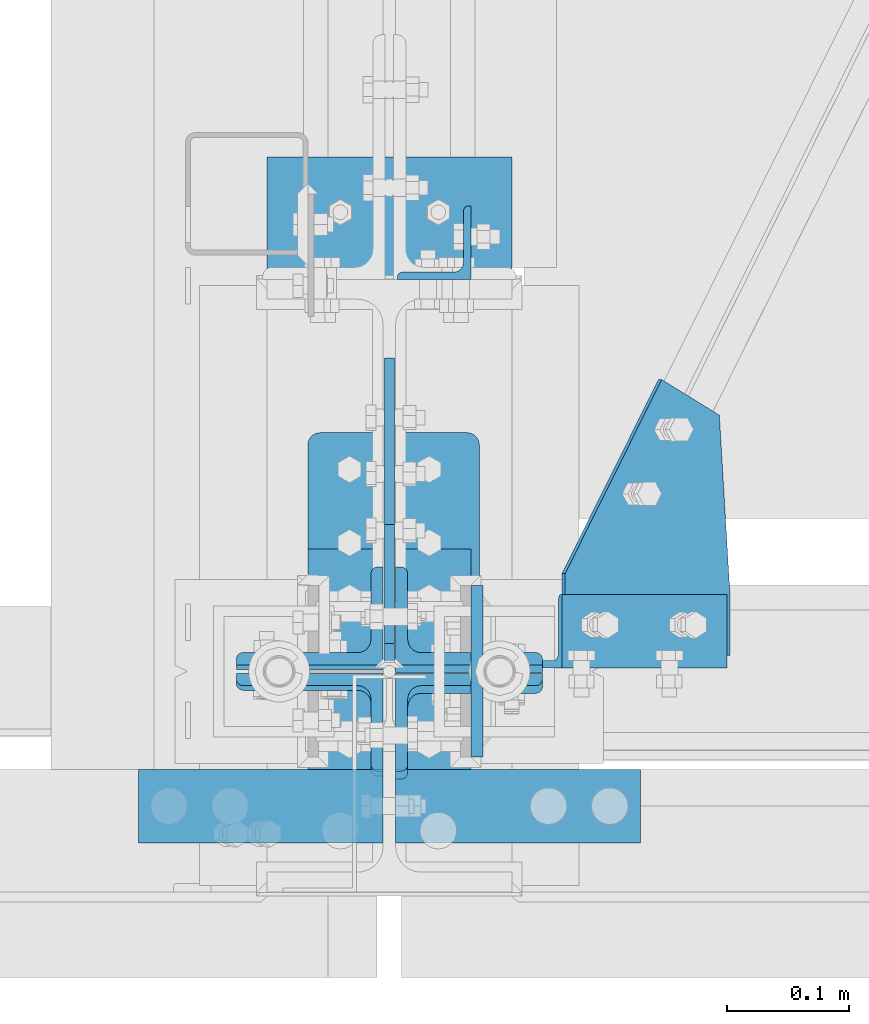
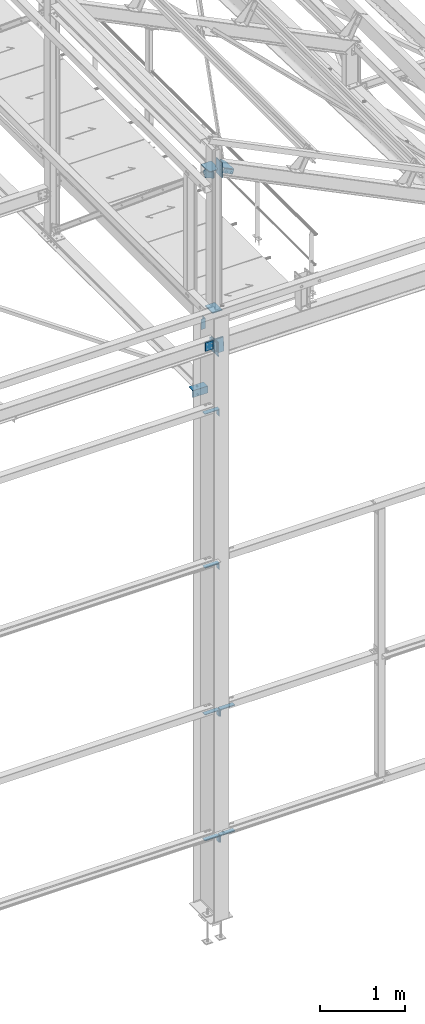
# One storey, part 101 of 496: 13 beams, 5 members, 16 elements without a shape of their own.
"""IFC2X3 building model written with IfcOpenShell, lengths in millimetres."""

from ifc_helpers import new_model, si_unit, frame, frame_2d, origin_with_axes, origin_2d_with_axis, place, context, subcontext, project, spatial, polyline, circle_curve, parameter, trimmed, segment, composite_curve, rectangle, l_section, outline, extrude, clip, halfspace, material, type_object, element, aggregate, save


model = new_model("IFC2X3")

# Units and contexts
model_context = context("Model", 3, precision=1e-05, world=origin_with_axes())
body_context = subcontext(model_context, "Body", "Model", "MODEL_VIEW")
ifc_project = project(units=[si_unit("LENGTHUNIT", "METRE", prefix="MILLI"), si_unit("AREAUNIT", "SQUARE_METRE"), si_unit("VOLUMEUNIT", "CUBIC_METRE"), si_unit("MASSUNIT", "GRAM", prefix="KILO"), si_unit("TIMEUNIT", "SECOND"), si_unit("PLANEANGLEUNIT", "RADIAN"), si_unit("SOLIDANGLEUNIT", "STERADIAN"), si_unit("THERMODYNAMICTEMPERATUREUNIT", "DEGREE_CELSIUS"), si_unit("LUMINOUSINTENSITYUNIT", "LUMEN")], contexts=[model_context])

# Site, building, storey
site_placement = place(None, origin_with_axes())
site = spatial("IfcSite", under=ifc_project, at=site_placement, CompositionType="ELEMENT")
building_placement = place(site_placement, origin_with_axes())
building = spatial("IfcBuilding", under=site, at=building_placement, Name="Undefined", CompositionType="ELEMENT")
storey_placement = place(building_placement, origin_with_axes())
storey = spatial("IfcBuildingStorey", under=building, at=storey_placement, Name="Undefined", CompositionType="ELEMENT", Elevation=0.0)

# Assembly, beam
assembly_1_placement = place(storey_placement, origin_with_axes())
assembly_1 = element("IfcElementAssembly", 1, at=assembly_1_placement, inside=storey, AssemblyPlace="NOTDEFINED", PredefinedType="NOTDEFINED")
ifc_material = material(Name="Undefined/S235-E24")
beam_type_1 = type_object("IfcBeamType", PredefinedType="NOTDEFINED")
beam_1_placement = place(assembly_1_placement, frame((34316.5000548681, 350.0, 8100.0), z_axis=(-1.0, 0.0, 0.0), x_axis=(0.0, 0.0, -1.0)))
beam_1 = element("IfcBeam", 2, at=beam_1_placement, type_object=beam_type_1, material=ifc_material, context=body_context, shape_type="SweptSolid", body=[
    extrude(l_section(Depth=60.0, Width=60.0, Thickness=6.0, FilletRadius=8.0, EdgeRadius=4.0, at=origin_2d_with_axis()), frame((149.999995982835, 4.54747350886464e-12, 3.63797880709171e-12), z_axis=(-1.0, 0.0, 0.0), x_axis=(0.0, -1.0, 0.0)), (0.0, 0.0, 1.0), 150.0),
])
aggregate(assembly_1, [beam_1])

# Assembly, member
assembly_2_placement = place(storey_placement, origin_with_axes())
assembly_2 = element("IfcElementAssembly", 3, at=assembly_2_placement, inside=storey, AssemblyPlace="NOTDEFINED", PredefinedType="NOTDEFINED")
member_type_1 = type_object("IfcMemberType", PredefinedType="NOTDEFINED")
member_1_placement = place(assembly_2_placement, frame((34542.3138840758, 33.0002237312074, 10309.8965662848), z_axis=(0.0, 1.0, 0.0), x_axis=(-0.897398510539055, -1.29999898490537e-08, 0.441220934773368)))
member_1 = element("IfcMember", 4, at=member_1_placement, type_object=member_type_1, material=ifc_material, context=body_context, shape_type="SweptSolid", body=[
    extrude(l_section(Depth=60.0, Width=60.0, Thickness=6.0, FilletRadius=8.0, EdgeRadius=4.0, at=origin_2d_with_axis()), frame((149.999995982835, 4.54747350886464e-12, 3.63797880709171e-12), z_axis=(-1.0, 0.0, 0.0), x_axis=(0.0, -1.0, 0.0)), (0.0, 0.0, 1.0), 150.0),
])
aggregate(assembly_2, [member_1])

# Assembly, beam
assembly_3_placement = place(storey_placement, origin_with_axes())
assembly_3 = element("IfcElementAssembly", 5, at=assembly_3_placement, inside=storey, Name="MONTANT", AssemblyPlace="NOTDEFINED", PredefinedType="NOTDEFINED")
beam_type_2 = type_object("IfcBeamType", PredefinedType="NOTDEFINED")
beam_2_placement = place(assembly_3_placement, frame((34280.0, 99.9999999999998, 8455.0), z_axis=(1.0, 0.0, 0.0), x_axis=(0.0, -1.0, 0.0)))
beam_2 = element("IfcBeam", 6, at=beam_2_placement, type_object=beam_type_2, material=ifc_material, context=body_context, shape_type="Clipping", body=[
    clip(extrude(rectangle(XDim=10.0, YDim=133.0, at=origin_2d_with_axis()), frame((200.0, 0.0, 0.0), z_axis=(-1.0, 0.0, 0.0), x_axis=(0.0, -1.0, 0.0)), (0.0, 0.0, 1.0), 200.0), halfspace(frame((180.0, -5.0, -66.5), z_axis=(1.0, 0.0, 0.0), x_axis=(0.0, 0.0, 1.0)), False)),
])

assembly_4_placement = place(storey_placement, origin_with_axes())
assembly_4 = element("IfcElementAssembly", 7, at=assembly_4_placement, inside=storey, AssemblyPlace="NOTDEFINED", PredefinedType="NOTDEFINED")
beam_type_3 = type_object("IfcBeamType", PredefinedType="NOTDEFINED")
beam_3_placement = place(assembly_4_placement, frame((34175.0000025058, -80.000006660929, 7050.000034965), z_axis=(-1.0, 0.0, 0.0), x_axis=(0.0, -1.0, 0.0)))
beam_3 = element("IfcBeam", 8, at=beam_3_placement, type_object=beam_type_3, material=ifc_material, context=body_context, shape_type="SweptSolid", body=[
    extrude(l_section(Depth=200.0, Width=100.0, Thickness=10.0, FilletRadius=15.0, EdgeRadius=7.5, at=origin_2d_with_axis()), frame((60.0, 0.0, 0.0), z_axis=(-1.0, 0.0, 0.0), x_axis=(0.0, -1.0, 0.0)), (0.0, 0.0, 1.0), 60.0),
])
aggregate(assembly_4, [beam_3])

assembly_5_placement = place(storey_placement, origin_with_axes())
assembly_5 = element("IfcElementAssembly", 9, at=assembly_5_placement, inside=storey, AssemblyPlace="NOTDEFINED", PredefinedType="NOTDEFINED")
beam_4_placement = place(assembly_5_placement, frame((34175.0000032068, -80.000006660929, 4850.00003496858), z_axis=(-1.0, 0.0, 0.0), x_axis=(0.0, -1.0, 0.0)))
beam_4 = element("IfcBeam", 10, at=beam_4_placement, type_object=beam_type_3, material=ifc_material, context=body_context, shape_type="SweptSolid", body=[
    extrude(l_section(Depth=200.0, Width=100.0, Thickness=10.0, FilletRadius=15.0, EdgeRadius=7.5, at=origin_2d_with_axis()), frame((60.0, 0.0, 0.0), z_axis=(-1.0, 0.0, 0.0), x_axis=(0.0, -1.0, 0.0)), (0.0, 0.0, 1.0), 60.0),
])
aggregate(assembly_5, [beam_4])

assembly_6_placement = place(storey_placement, origin_with_axes())
assembly_6 = element("IfcElementAssembly", 11, at=assembly_6_placement, inside=storey, AssemblyPlace="NOTDEFINED", PredefinedType="NOTDEFINED")
beam_5_placement = place(assembly_6_placement, frame((34175.0000025058, -80.000006660929, 2750.000034965), z_axis=(-1.0, 0.0, 0.0), x_axis=(0.0, -1.0, 0.0)))
beam_5 = element("IfcBeam", 12, at=beam_5_placement, type_object=beam_type_3, material=ifc_material, context=body_context, shape_type="SweptSolid", body=[
    extrude(l_section(Depth=200.0, Width=100.0, Thickness=10.0, FilletRadius=15.0, EdgeRadius=7.5, at=origin_2d_with_axis()), frame((60.0, 0.0, 0.0), z_axis=(-1.0, 0.0, 0.0), x_axis=(0.0, -1.0, 0.0)), (0.0, 0.0, 1.0), 60.0),
])
aggregate(assembly_6, [beam_5])

assembly_7_placement = place(storey_placement, origin_with_axes())
assembly_7 = element("IfcElementAssembly", 13, at=assembly_7_placement, inside=storey, AssemblyPlace="NOTDEFINED", PredefinedType="NOTDEFINED")
beam_6_placement = place(assembly_7_placement, frame((34385.0000023856, -140.000007080964, 2750.000034965), z_axis=(1.0, 0.0, 0.0), x_axis=(0.0, 1.0, 0.0)))
beam_6 = element("IfcBeam", 14, at=beam_6_placement, type_object=beam_type_3, material=ifc_material, context=body_context, shape_type="SweptSolid", body=[
    extrude(l_section(Depth=200.0, Width=100.0, Thickness=10.0, FilletRadius=15.0, EdgeRadius=7.5, at=origin_2d_with_axis()), frame((60.0, 0.0, 0.0), z_axis=(-1.0, 0.0, 0.0), x_axis=(0.0, -1.0, 0.0)), (0.0, 0.0, 1.0), 60.0),
])
aggregate(assembly_7, [beam_6])

assembly_8_placement = place(storey_placement, origin_with_axes())
assembly_8 = element("IfcElementAssembly", 15, at=assembly_8_placement, inside=storey, AssemblyPlace="NOTDEFINED", PredefinedType="NOTDEFINED")
beam_7_placement = place(assembly_8_placement, frame((34175.0000032068, -80.000006660929, 950.000034966312), z_axis=(-1.0, 0.0, 0.0), x_axis=(0.0, -1.0, 0.0)))
beam_7 = element("IfcBeam", 16, at=beam_7_placement, type_object=beam_type_3, material=ifc_material, context=body_context, shape_type="SweptSolid", body=[
    extrude(l_section(Depth=200.0, Width=100.0, Thickness=10.0, FilletRadius=15.0, EdgeRadius=7.5, at=origin_2d_with_axis()), frame((60.0, 0.0, 0.0), z_axis=(-1.0, 0.0, 0.0), x_axis=(0.0, -1.0, 0.0)), (0.0, 0.0, 1.0), 60.0),
])
aggregate(assembly_8, [beam_7])

assembly_9_placement = place(storey_placement, origin_with_axes())
assembly_9 = element("IfcElementAssembly", 17, at=assembly_9_placement, inside=storey, AssemblyPlace="NOTDEFINED", PredefinedType="NOTDEFINED")
beam_8_placement = place(assembly_9_placement, frame((34385.0000030867, -140.000007080964, 950.000034966312), z_axis=(1.0, 0.0, 0.0), x_axis=(0.0, 1.0, 0.0)))
beam_8 = element("IfcBeam", 18, at=beam_8_placement, type_object=beam_type_3, material=ifc_material, context=body_context, shape_type="SweptSolid", body=[
    extrude(l_section(Depth=200.0, Width=100.0, Thickness=10.0, FilletRadius=15.0, EdgeRadius=7.5, at=origin_2d_with_axis()), frame((60.0, 0.0, 0.0), z_axis=(-1.0, 0.0, 0.0), x_axis=(0.0, -1.0, 0.0)), (0.0, 0.0, 1.0), 60.0),
])
aggregate(assembly_9, [beam_8])

assembly_10_placement = place(storey_placement, origin_with_axes())
assembly_10 = element("IfcElementAssembly", 19, at=assembly_10_placement, inside=storey, Name="TRAVERSE SHED", AssemblyPlace="NOTDEFINED", PredefinedType="NOTDEFINED")
beam_type_4 = type_object("IfcBeamType", PredefinedType="NOTDEFINED")
beam_9_placement = place(assembly_10_placement, frame((34351.5, 0.0, 10548.0682550821), z_axis=(0.0, -1.0, 0.0), x_axis=(0.0, 0.0, -1.0)))
beam_9 = element("IfcBeam", 20, at=beam_9_placement, type_object=beam_type_4, material=ifc_material, context=body_context, shape_type="SweptSolid", body=[
    extrude(rectangle(XDim=10.0, YDim=140.0, at=origin_2d_with_axis()), frame((213.394604237721, 0.0, 0.0), z_axis=(-1.0, 0.0, 0.0), x_axis=(0.0, -1.0, 0.0)), (0.0, 0.0, 1.0), 213.39),
])
aggregate(assembly_10, [beam_9])

assembly_11_placement = place(storey_placement, origin_with_axes())
assembly_11 = element("IfcElementAssembly", 21, at=assembly_11_placement, inside=storey, AssemblyPlace="NOTDEFINED", PredefinedType="NOTDEFINED")
beam_type_5 = type_object("IfcBeamType", PredefinedType="NOTDEFINED")
beam_10_placement = place(assembly_11_placement, frame((34548.1682777578, 209.258937946682, 10343.7911863879), z_axis=(0.441221071222121, 0.0, 0.897398443451739), x_axis=(-0.784869556946141, 0.484835704476116, 0.38589392097352)))
beam_10 = element("IfcBeam", 22, at=beam_10_placement, type_object=beam_type_5, material=ifc_material, context=body_context, shape_type="SweptSolid", body=[
    extrude(outline(polyline([(0.0, 0.0), (60.0, 0.0), (60.000000001357, 181.13842773447), (27.5527534497232, 239.6707305907), (-103.638031004382, 166.945343016534), (-79.3962478622052, 123.215103148526), (0.0, 0.0)])), frame((0.0, 0.0, -3.0), z_axis=(0.0, 0.0, 1.0), x_axis=(1.0, 0.0, 0.0)), (0.0, 0.0, 1.0), 6.0),
])
aggregate(assembly_11, [beam_10])

# Assembly, member
assembly_12_placement = place(storey_placement, origin_with_axes())
assembly_12 = element("IfcElementAssembly", 23, at=assembly_12_placement, inside=storey, AssemblyPlace="NOTDEFINED", PredefinedType="NOTDEFINED")
member_type_2 = type_object("IfcMemberType", PredefinedType="NOTDEFINED")
member_2_placement = place(assembly_12_placement, frame((34344.9994948936, 39.0795813973484, 7808.65680402093), z_axis=(1.0, 0.0, 0.0), x_axis=(0.0, 0.031410887010906, 0.999506556345274)))
member_2 = element("IfcMember", 24, at=member_2_placement, type_object=member_type_2, material=ifc_material, context=body_context, shape_type="SweptSolid", body=[
    extrude(l_section(Depth=120.0, Width=80.0, Thickness=10.0, FilletRadius=11.0, EdgeRadius=5.5, at=origin_2d_with_axis()), frame((200.0, 0.0, 0.0), z_axis=(-1.0, 0.0, 0.0), x_axis=(0.0, -1.0, 0.0)), (0.0, 0.0, 1.0), 200.0),
])
aggregate(assembly_12, [member_2])

assembly_13_placement = place(storey_placement, origin_with_axes())
assembly_13 = element("IfcElementAssembly", 25, at=assembly_13_placement, inside=storey, AssemblyPlace="NOTDEFINED", PredefinedType="NOTDEFINED")
member_3_placement = place(assembly_13_placement, frame((34344.9994948937, -41.5961426559995, 8011.2909028725), z_axis=(1.0, 0.0, 0.0), x_axis=(0.0, -0.031410887010906, -0.999506556345274)))
member_3 = element("IfcMember", 26, at=member_3_placement, type_object=member_type_2, material=ifc_material, context=body_context, shape_type="SweptSolid", body=[
    extrude(l_section(Depth=120.0, Width=80.0, Thickness=10.0, FilletRadius=11.0, EdgeRadius=5.5, at=origin_2d_with_axis()), frame((200.0, 0.0, 0.0), z_axis=(-1.0, 0.0, 0.0), x_axis=(0.0, -1.0, 0.0)), (0.0, 0.0, 1.0), 200.0),
])
aggregate(assembly_13, [member_3])

assembly_14_placement = place(storey_placement, origin_with_axes())
assembly_14 = element("IfcElementAssembly", 27, at=assembly_14_placement, inside=storey, AssemblyPlace="NOTDEFINED", PredefinedType="NOTDEFINED")
member_4_placement = place(assembly_14_placement, frame((34214.9978557686, 45.3617889351294, 8008.55810716617), z_axis=(-1.0, 0.0, 0.0), x_axis=(0.0, -0.031410887010906, -0.999506556345274)))
member_4 = element("IfcMember", 28, at=member_4_placement, type_object=member_type_2, material=ifc_material, context=body_context, shape_type="SweptSolid", body=[
    extrude(l_section(Depth=120.0, Width=80.0, Thickness=10.0, FilletRadius=11.0, EdgeRadius=5.5, at=origin_2d_with_axis()), frame((120.0, 0.0, 0.0), z_axis=(-1.0, 0.0, 0.0), x_axis=(0.0, -1.0, 0.0)), (0.0, 0.0, 1.0), 120.0),
])
aggregate(assembly_14, [member_4])

assembly_15_placement = place(storey_placement, origin_with_axes())
assembly_15 = element("IfcElementAssembly", 29, at=assembly_15_placement, inside=storey, AssemblyPlace="NOTDEFINED", PredefinedType="NOTDEFINED")
member_5_placement = place(assembly_15_placement, frame((34214.9978557687, -45.365488593566, 7891.35012452894), z_axis=(-1.0, 0.0, 0.0), x_axis=(0.0, 0.031410887010906, 0.999506556345274)))
member_5 = element("IfcMember", 30, at=member_5_placement, type_object=member_type_2, material=ifc_material, context=body_context, shape_type="SweptSolid", body=[
    extrude(l_section(Depth=120.0, Width=80.0, Thickness=10.0, FilletRadius=11.0, EdgeRadius=5.5, at=origin_2d_with_axis()), frame((120.0, 0.0, 0.0), z_axis=(-1.0, 0.0, 0.0), x_axis=(0.0, -1.0, 0.0)), (0.0, 0.0, 1.0), 120.0),
])
aggregate(assembly_15, [member_5])

# Assembly, beam
assembly_16_placement = place(storey_placement, origin_with_axes())
assembly_16 = element("IfcElementAssembly", 31, at=assembly_16_placement, inside=storey, AssemblyPlace="NOTDEFINED", PredefinedType="NOTDEFINED")
beam_type_6 = type_object("IfcBeamType", PredefinedType="NOTDEFINED")
beam_11_placement = place(assembly_16_placement, frame((34179.999231425, 369.998029381188, 7067.00000007623), z_axis=(0.0, 0.0, -1.0), x_axis=(0.999999999883108, 1.52899999980981e-05, 0.0)))
beam_11 = element("IfcBeam", 32, at=beam_11_placement, type_object=beam_type_6, material=ifc_material, context=body_context, shape_type="SweptSolid", body=[
    extrude(l_section(Depth=100.0, Width=100.0, Thickness=10.0, FilletRadius=12.0, EdgeRadius=6.0, at=origin_2d_with_axis()), frame((200.0, 0.0, 0.0), z_axis=(-1.0, 0.0, 0.0), x_axis=(0.0, -1.0, 0.0)), (0.0, 0.0, 1.0), 200.0),
])
aggregate(assembly_16, [beam_11])

# Beam
beam_type_7 = type_object("IfcBeamType", PredefinedType="NOTDEFINED")
beam_12_placement = place(assembly_3_placement, frame((34280.0, 2.75000000000074, 10413.0), z_axis=(-1.0, 0.0, 0.0), x_axis=(0.0, 1.0, 0.0)))
beam_12 = element("IfcBeam", 33, at=beam_12_placement, type_object=beam_type_7, material=ifc_material, context=body_context, shape_type="SweptSolid", body=[
    extrude(outline(polyline([(0.0, 20.0), (20.0, 0.0), (117.25, 0.0), (253.170501708984, 151.578247070313), (201.895324707031, 212.985534667969), (0.0, 100.0), (0.0, 20.0)])), frame((0.0, 0.0, -4.0), z_axis=(0.0, 0.0, 1.0), x_axis=(1.0, 0.0, 0.0)), (0.0, 0.0, 1.0), 8.0),
])

beam_type_8 = type_object("IfcBeamType", PredefinedType="NOTDEFINED")
beam_13_placement = place(assembly_3_placement, frame((34213.5, 195.000000000001, 10418.0), z_axis=(0.0, 0.0, 1.0), x_axis=(0.0, -1.0, 0.0)))
beam_13 = element("IfcBeam", 34, at=beam_13_placement, type_object=beam_type_8, material=ifc_material, Name="PLAT", context=body_context, shape_type="SweptSolid", body=[
    extrude(outline(composite_curve([segment(trimmed(circle_curve(frame_2d((10.0, 10.0), x_axis=(-1.0, 0.0)), 10.0), [parameter(0.0)], [parameter(1.5707963267949)], True, "PARAMETER"), True, "CONTINUOUS"), segment(polyline([(9.99999999997453, 6.91215973347425e-11), (124.5, 0.0), (124.5, 9.0), (172.25, 9.0), (192.25, 29.0), (192.25, 104.0), (172.25, 124.0), (124.0, 124.0), (124.0, 140.0), (10.0, 140.0)]), True, "CONTINUOUS"), segment(trimmed(circle_curve(frame_2d((10.0, 130.0), x_axis=(0.0, 1.0)), 10.0), [parameter(0.0)], [parameter(1.5707963267949)], True, "PARAMETER"), True, "CONTINUOUS"), segment(polyline([(0.0, 130.0), (-1.81898940354586e-10, 10.0000000000073)]), True, "CONTINUOUS")], self_intersect=True)), frame((0.0, 0.0, -5.0), z_axis=(0.0, 0.0, 1.0), x_axis=(1.0, 0.0, 0.0)), (0.0, 0.0, 1.0), 10.0),
])

aggregate(assembly_3, [beam_12, beam_2, beam_13])

save(model, "model.ifc")
